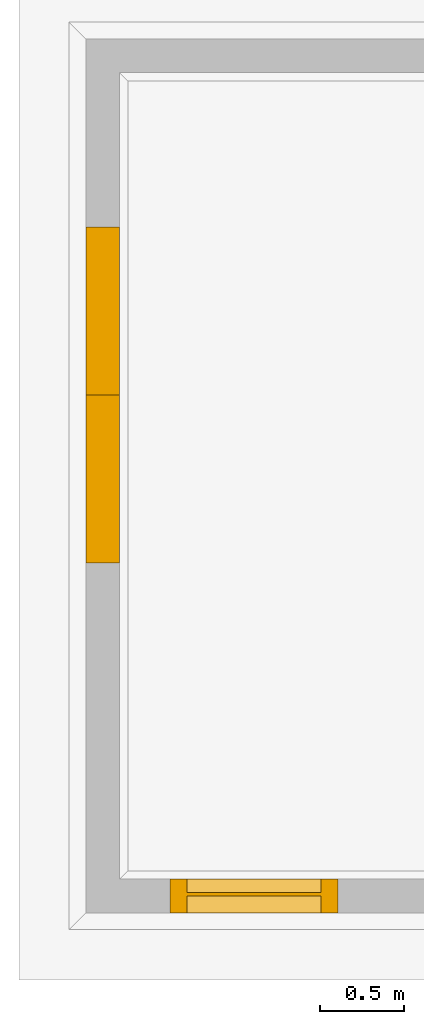
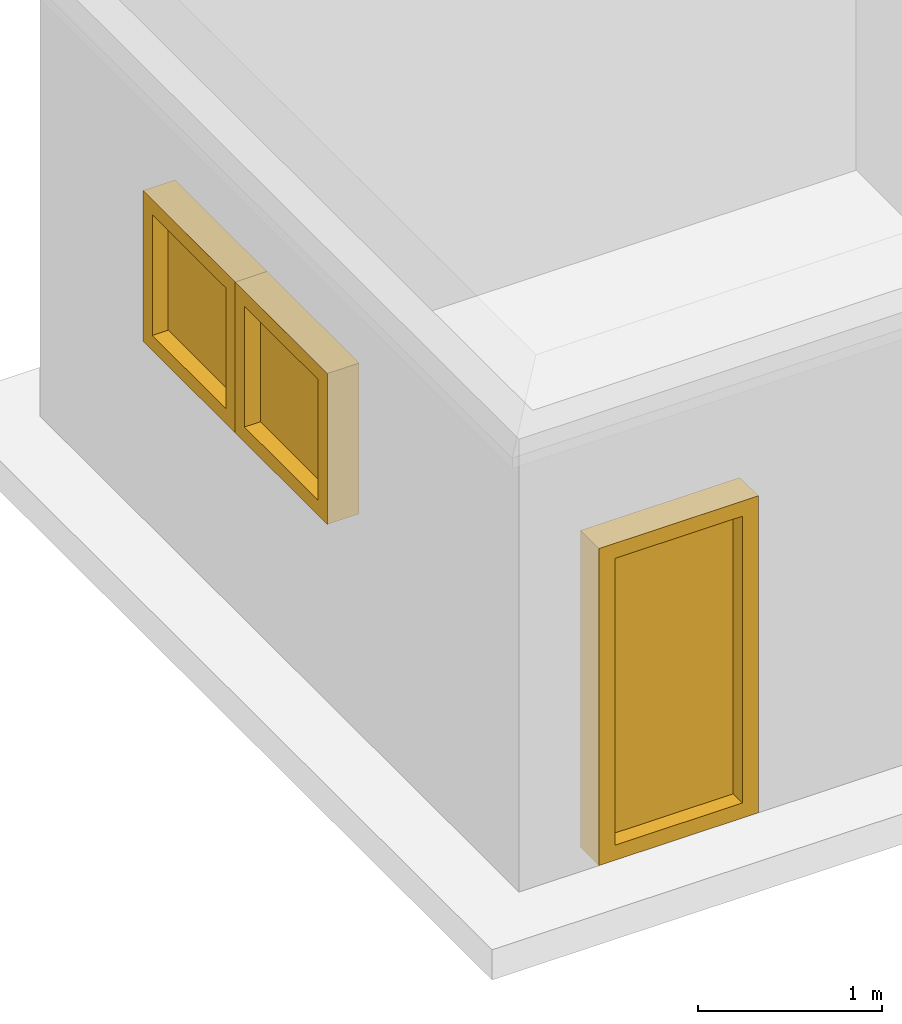
# Not in any storey, part 3 of 3: 3 windows.
"""IFC4 building model written with IfcOpenShell, lengths in metres."""

from ifc_helpers import new_model, entity, si_unit, converted_unit, direction, origin_with_axes, place, context, subcontext, project, spatial, faceted_brep, element, save


model = new_model("IFC4")

# Units and contexts
model_context = context("Model", 3, precision=1e-05, world=origin_with_axes(), true_north=direction((0.0, 1.0)))
body_context = subcontext(model_context, "Body", "Model", "MODEL_VIEW")
ifc_project = project(units=[si_unit("LENGTHUNIT", "METRE"), si_unit("AREAUNIT", "SQUARE_METRE"), si_unit("VOLUMEUNIT", "CUBIC_METRE"), converted_unit("PLANEANGLEUNIT", "DEGREE", entity("IfcPlaneAngleMeasure", 0.017453292519943295), si_unit("PLANEANGLEUNIT", "RADIAN"), dimensions=[0, 0, 0, 0, 0, 0, 0])], contexts=[model_context])

# Building
building = spatial("IfcBuilding", CompositionType="COMPLEX")

# Windows
placement = place(None, origin_with_axes())
element("IfcWindow", 1, at=placement, inside=building, OverallHeight=1000.0, OverallWidth=1000.0, PartitioningType="SINGLE_PANEL", PredefinedType="WINDOW", context=body_context, shape_type="Brep", body=[
    faceted_brep([(-0.1, 3.9806728515625, 1.17355590820313), (0.1, 3.9806728515625, 1.17355590820313), (0.1, 2.9806728515625, 1.17355590820313), (-0.1, 2.9806728515625, 1.17355590820313), (-0.1, 3.9806728515625, 2.17355590820313), (0.1, 3.9806728515625, 2.17355590820313), (0.1, 2.9806728515625, 2.17355590820313), (-0.1, 2.9806728515625, 2.17355590820313), (-0.1, 3.0806728515625, 1.27355590820312), (-0.1, 3.8806728515625, 1.27355590820312), (-0.1, 3.8806728515625, 2.07355590820312), (-0.1, 3.0806728515625, 2.07355590820312), (0.1, 3.8806728515625, 1.27355590820312), (0.1, 3.0806728515625, 1.27355590820312), (0.1, 3.0806728515625, 2.07355590820312), (0.1, 3.8806728515625, 2.07355590820312)], [[[0, 1, 2, 3]], [[4, 5, 1, 0]], [[3, 2, 6, 7]], [[0, 3, 7, 4], [8, 9, 10, 11]], [[5, 6, 2, 1], [12, 13, 14, 15]], [[7, 6, 5, 4]], [[8, 13, 12, 9]], [[11, 14, 13, 8]], [[10, 15, 14, 11]], [[9, 12, 15, 10]]]),
    faceted_brep([(0.0, 3.8806728515625, 1.27355590820312), (0.02, 3.8806728515625, 1.27355590820312), (0.02, 3.0806728515625, 1.27355590820312), (0.0, 3.0806728515625, 1.27355590820312), (0.02, 3.0806728515625, 2.07355590820312), (0.0, 3.0806728515625, 2.07355590820312), (0.02, 3.8806728515625, 2.07355590820312), (0.0, 3.8806728515625, 2.07355590820312)], [[[0, 1, 2, 3]], [[3, 2, 4, 5]], [[5, 4, 6, 7]], [[7, 6, 1, 0]], [[0, 3, 5, 7]], [[6, 4, 2, 1]]]),
])
element("IfcWindow", 2, at=placement, inside=building, Name="001", OverallHeight=1000.0, OverallWidth=1000.0, PartitioningType="SINGLE_PANEL", PredefinedType="WINDOW", context=body_context, shape_type="Brep", body=[
    faceted_brep([(-0.1, 2.9806728515625, 1.17355590820313), (0.1, 2.9806728515625, 1.17355590820313), (0.1, 1.9806728515625, 1.17355590820313), (-0.1, 1.9806728515625, 1.17355590820313), (-0.1, 2.9806728515625, 2.17355590820313), (0.1, 2.9806728515625, 2.17355590820313), (0.1, 1.9806728515625, 2.17355590820313), (-0.1, 1.9806728515625, 2.17355590820313), (-0.1, 2.0806728515625, 1.27355590820312), (-0.1, 2.8806728515625, 1.27355590820312), (-0.1, 2.8806728515625, 2.07355590820312), (-0.1, 2.0806728515625, 2.07355590820312), (0.1, 2.8806728515625, 1.27355590820312), (0.1, 2.0806728515625, 1.27355590820312), (0.1, 2.0806728515625, 2.07355590820312), (0.1, 2.8806728515625, 2.07355590820312)], [[[0, 1, 2, 3]], [[4, 5, 1, 0]], [[3, 2, 6, 7]], [[0, 3, 7, 4], [8, 9, 10, 11]], [[5, 6, 2, 1], [12, 13, 14, 15]], [[7, 6, 5, 4]], [[8, 13, 12, 9]], [[11, 14, 13, 8]], [[10, 15, 14, 11]], [[9, 12, 15, 10]]]),
    faceted_brep([(0.0, 2.8806728515625, 1.27355590820312), (0.02, 2.8806728515625, 1.27355590820312), (0.02, 2.0806728515625, 1.27355590820312), (0.0, 2.0806728515625, 1.27355590820312), (0.02, 2.0806728515625, 2.07355590820312), (0.0, 2.0806728515625, 2.07355590820312), (0.02, 2.8806728515625, 2.07355590820312), (0.0, 2.8806728515625, 2.07355590820312)], [[[0, 1, 2, 3]], [[3, 2, 4, 5]], [[5, 4, 6, 7]], [[7, 6, 1, 0]], [[0, 3, 5, 7]], [[6, 4, 2, 1]]]),
])
element("IfcWindow", 3, at=placement, inside=building, Name="002", OverallHeight=2100.0, OverallWidth=1000.0, PartitioningType="SINGLE_PANEL", PredefinedType="WINDOW", context=body_context, shape_type="Brep", body=[
    faceted_brep([(0.4, -0.1, 0.0), (0.4, 0.1, -4.4e-17), (1.4, 0.1, -4.4e-17), (1.4, -0.1, 0.0), (0.4, -0.1, 2.1), (0.4, 0.1, 2.1), (1.4, 0.1, 2.1), (1.4, -0.1, 2.1), (1.3, -0.1, 0.1), (0.5, -0.1, 0.1), (0.5, -0.1, 2.0), (1.3, -0.1, 2.0), (0.5, 0.1, 0.1), (1.3, 0.1, 0.1), (1.3, 0.1, 2.0), (0.5, 0.1, 2.0)], [[[0, 1, 2, 3]], [[4, 5, 1, 0]], [[3, 2, 6, 7]], [[0, 3, 7, 4], [8, 9, 10, 11]], [[5, 6, 2, 1], [12, 13, 14, 15]], [[7, 6, 5, 4]], [[8, 13, 12, 9]], [[11, 14, 13, 8]], [[10, 15, 14, 11]], [[9, 12, 15, 10]]]),
    faceted_brep([(0.5, 0.0, 0.1), (0.5, 0.02, 0.1), (1.3, 0.02, 0.1), (1.3, 0.0, 0.1), (1.3, 0.02, 2.0), (1.3, 0.0, 2.0), (0.5, 0.02, 2.0), (0.5, 0.0, 2.0)], [[[0, 1, 2, 3]], [[3, 2, 4, 5]], [[5, 4, 6, 7]], [[7, 6, 1, 0]], [[0, 3, 5, 7]], [[6, 4, 2, 1]]]),
])

save(model, "model.ifc")
